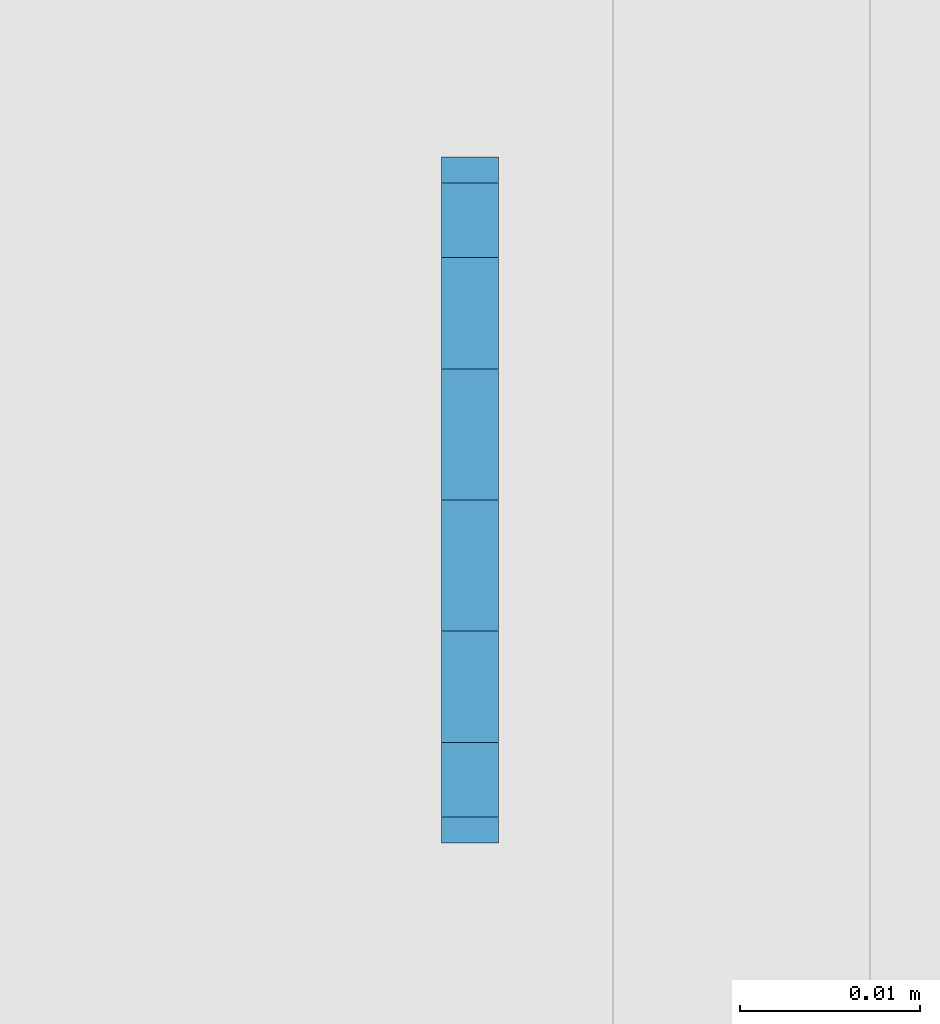
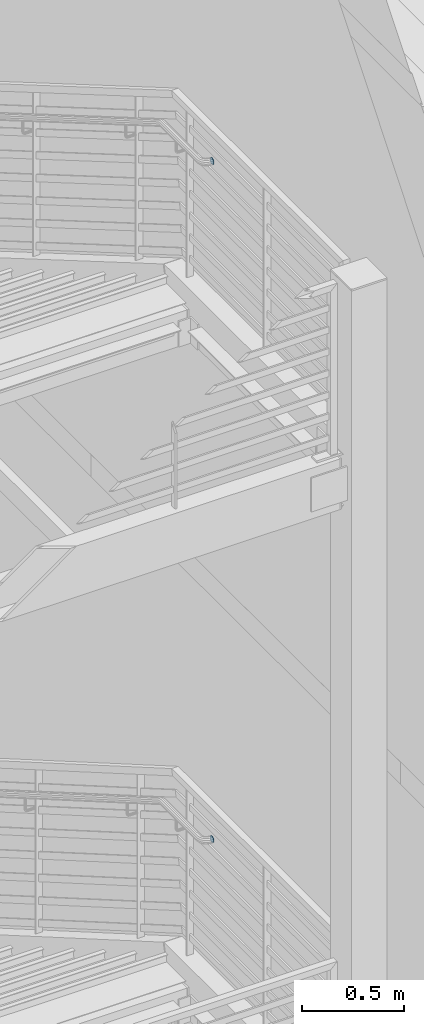
# One storey, part 1123 of 1179: 2 plates, 2 elements without a shape of their own.
"""IFC2X3 building model written with IfcOpenShell, lengths in millimetres."""

from ifc_helpers import new_model, si_unit, frame, origin_with_axes, place, context, subcontext, project, spatial, faceted_brep, material, type_object, element, aggregate, save


model = new_model("IFC2X3")

# Units and contexts
model_context = context("Model", 3, precision=1e-05, world=origin_with_axes())
body_context = subcontext(model_context, "Body", "Model", "MODEL_VIEW")
ifc_project = project(units=[si_unit("LENGTHUNIT", "METRE", prefix="MILLI"), si_unit("AREAUNIT", "SQUARE_METRE"), si_unit("VOLUMEUNIT", "CUBIC_METRE"), si_unit("MASSUNIT", "GRAM", prefix="KILO"), si_unit("TIMEUNIT", "SECOND"), si_unit("PLANEANGLEUNIT", "RADIAN"), si_unit("SOLIDANGLEUNIT", "STERADIAN"), si_unit("THERMODYNAMICTEMPERATUREUNIT", "DEGREE_CELSIUS"), si_unit("LUMINOUSINTENSITYUNIT", "LUMEN")], contexts=[model_context])

# Site, building, storey
site_placement = place(None, origin_with_axes())
site = spatial("IfcSite", under=ifc_project, at=site_placement, CompositionType="ELEMENT")
building_placement = place(site_placement, origin_with_axes())
building = spatial("IfcBuilding", under=site, at=building_placement, Name="Undefined", CompositionType="ELEMENT")
storey_placement = place(building_placement, origin_with_axes())
storey = spatial("IfcBuildingStorey", under=building, at=storey_placement, Name="Undefined", CompositionType="ELEMENT", Elevation=0.0)

# Assembly, plate
assembly_1_placement = place(storey_placement, origin_with_axes())
assembly_1 = element("IfcElementAssembly", 1, at=assembly_1_placement, inside=storey, Name="GUARDRAIL", AssemblyPlace="NOTDEFINED", PredefinedType="RIGID_FRAME")
ifc_material = material(Name="STEEL/A36")
plate_type = type_object("IfcPlateType", PredefinedType="NOTDEFINED")
plate_1_placement = place(assembly_1_placement, frame((-274.637499979518, 31464.2499999953, 7124.69999999814), z_axis=(0.0, 1.0, 0.0), x_axis=(0.0, 0.0, -1.0)))
plate_1 = element("IfcPlate", 2, at=plate_1_placement, type_object=plate_type, material=ifc_material, Name="PLATE", context=body_context, shape_type="Brep", body=[
    faceted_brep([(0.0, -1.58750000000146, 19.0499992370605), (1.4500948475843, -1.58750000000146, 26.3401198575302), (1.4500948475843, 1.58750000000146, 26.3401198575302), (0.0, 1.58750000000146, 19.0499992370605), (5.57961559493651, -1.58750000000146, 32.5203844050629), (5.57961559493651, 1.58750000000146, 32.5203844050629), (11.7598801424701, -1.58750000000146, 36.6499051524152), (11.7598801424701, 1.58750000000146, 36.6499051524152), (19.0500007629398, -1.58750000000146, 38.0999999999985), (19.0500007629398, 1.58750000000146, 38.0999999999985), (26.3401198575302, -1.58750000000146, 36.6499051524152), (26.3401198575302, 1.58750000000146, 36.6499051524152), (32.5203844050639, -1.58750000000146, 32.5203844050629), (32.5203844050639, 1.58750000000146, 32.5203844050629), (36.6499051524161, -1.58750000000146, 26.3401198575302), (36.6499051524161, 1.58750000000146, 26.3401198575302), (38.1000000000004, -1.58750000000146, 19.0499992370605), (38.1000000000004, 1.58750000000146, 19.0499992370605), (36.6499051524161, -1.58750000000146, 11.7598801424683), (36.6499051524161, 1.58750000000146, 11.7598801424683), (32.5203844050639, -1.58750000000146, 5.5796155949356), (32.5203844050639, 1.58750000000146, 5.5796155949356), (26.3401198575302, -1.58750000000146, 1.45009484758339), (26.3401198575302, 1.58750000000146, 1.45009484758339), (19.0499992370605, -1.58750000000146, 0.0), (19.0499992370605, 1.58750000000146, 0.0), (11.7598801424701, -1.58750000000146, 1.45009484758339), (11.7598801424701, 1.58750000000146, 1.45009484758339), (5.57961559493651, -1.58750000000146, 5.5796155949356), (5.57961559493651, 1.58750000000146, 5.5796155949356), (1.4500948475843, -1.58750000000146, 11.7598801424683), (1.4500948475843, 1.58750000000146, 11.7598801424683)], [[[0, 1, 2, 3]], [[1, 4, 5, 2]], [[4, 6, 7, 5]], [[6, 8, 9, 7]], [[8, 10, 11, 9]], [[10, 12, 13, 11]], [[12, 14, 15, 13]], [[14, 16, 17, 15]], [[16, 18, 19, 17]], [[18, 20, 21, 19]], [[20, 22, 23, 21]], [[22, 24, 25, 23]], [[24, 26, 27, 25]], [[26, 28, 29, 27]], [[28, 30, 31, 29]], [[30, 0, 3, 31]], [[5, 7, 9, 11, 13, 15, 17, 19, 21, 23, 25, 27, 29, 31, 3, 2]], [[30, 28, 26, 24, 22, 20, 18, 16, 14, 12, 10, 8, 6, 4, 1, 0]]]),
])
aggregate(assembly_1, [plate_1])

assembly_2_placement = place(storey_placement, origin_with_axes())
assembly_2 = element("IfcElementAssembly", 3, at=assembly_2_placement, inside=storey, Name="GUARDRAIL", AssemblyPlace="NOTDEFINED", PredefinedType="RIGID_FRAME")
plate_2_placement = place(assembly_2_placement, frame((-274.637499979519, 31464.2500001211, 3051.22791904202), z_axis=(0.0, 1.0, 0.0), x_axis=(0.0, 0.0, -1.0)))
plate_2 = element("IfcPlate", 4, at=plate_2_placement, type_object=plate_type, material=ifc_material, Name="PLATE", context=body_context, shape_type="Brep", body=[
    faceted_brep([(0.0, -1.58750000000146, 19.0499992370605), (1.4500948475843, -1.58750000000146, 26.3401198575302), (1.4500948475843, 1.58750000000146, 26.3401198575302), (0.0, 1.58750000000146, 19.0499992370605), (5.57961559493651, -1.58750000000146, 32.5203844050629), (5.57961559493651, 1.58750000000146, 32.5203844050629), (11.7598801424701, -1.58750000000146, 36.6499051524152), (11.7598801424701, 1.58750000000146, 36.6499051524152), (19.0500007629398, -1.58750000000146, 38.0999999999985), (19.0500007629398, 1.58750000000146, 38.0999999999985), (26.3401198575302, -1.58750000000146, 36.6499051524152), (26.3401198575302, 1.58750000000146, 36.6499051524152), (32.5203844050639, -1.58750000000146, 32.5203844050629), (32.5203844050639, 1.58750000000146, 32.5203844050629), (36.6499051524161, -1.58750000000146, 26.3401198575302), (36.6499051524161, 1.58750000000146, 26.3401198575302), (38.1000000000004, -1.58750000000146, 19.0499992370605), (38.1000000000004, 1.58750000000146, 19.0499992370605), (36.6499051524161, -1.58750000000146, 11.7598801424683), (36.6499051524161, 1.58750000000146, 11.7598801424683), (32.5203844050639, -1.58750000000146, 5.5796155949356), (32.5203844050639, 1.58750000000146, 5.5796155949356), (26.3401198575302, -1.58750000000146, 1.45009484758339), (26.3401198575302, 1.58750000000146, 1.45009484758339), (19.0499992370605, -1.58750000000146, 0.0), (19.0499992370605, 1.58750000000146, 0.0), (11.7598801424701, -1.58750000000146, 1.45009484758339), (11.7598801424701, 1.58750000000146, 1.45009484758339), (5.57961559493651, -1.58750000000146, 5.5796155949356), (5.57961559493651, 1.58750000000146, 5.5796155949356), (1.4500948475843, -1.58750000000146, 11.7598801424683), (1.4500948475843, 1.58750000000146, 11.7598801424683)], [[[0, 1, 2, 3]], [[1, 4, 5, 2]], [[4, 6, 7, 5]], [[6, 8, 9, 7]], [[8, 10, 11, 9]], [[10, 12, 13, 11]], [[12, 14, 15, 13]], [[14, 16, 17, 15]], [[16, 18, 19, 17]], [[18, 20, 21, 19]], [[20, 22, 23, 21]], [[22, 24, 25, 23]], [[24, 26, 27, 25]], [[26, 28, 29, 27]], [[28, 30, 31, 29]], [[30, 0, 3, 31]], [[5, 7, 9, 11, 13, 15, 17, 19, 21, 23, 25, 27, 29, 31, 3, 2]], [[30, 28, 26, 24, 22, 20, 18, 16, 14, 12, 10, 8, 6, 4, 1, 0]]]),
])
aggregate(assembly_2, [plate_2])

save(model, "model.ifc")
